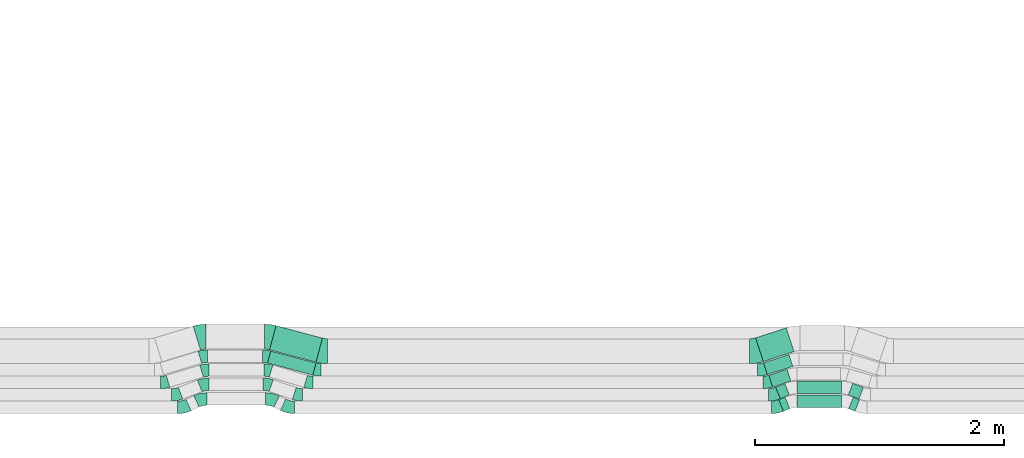
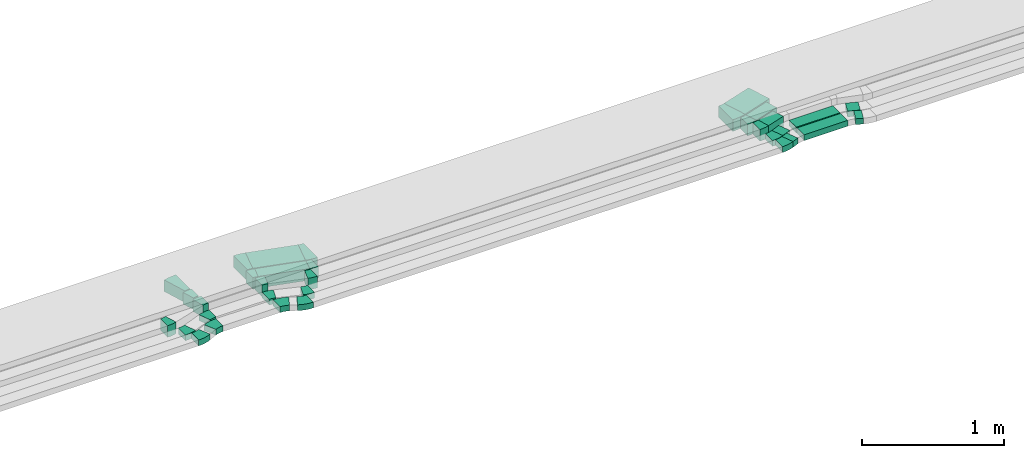
# One storey, part 12 of 28: 23 flow fittings, 11 flow segments.
"""IFC2X3 building model written with IfcOpenShell, lengths in millimetres."""

from ifc_helpers import new_model, entity, si_unit, converted_unit, derived_unit, direction, frame, frame_2d, origin, origin_2d_with_axis, place, context, subcontext, project, spatial, polyline, circle_curve, parameter, trimmed, segment, composite_curve, rectangle, outline, extrude, source, transform, mapped, material, type_object, type_shapes, element, save


model = new_model("IFC2X3")

# Units and contexts
model_context = context("Model", 3, precision=0.01, world=origin(), true_north=direction((6.12303176911189e-17, 1.0)))
body_context = subcontext(model_context, "Body", "Model", "MODEL_VIEW")
ifc_project = project(units=[si_unit("LENGTHUNIT", "METRE", prefix="MILLI"), si_unit("AREAUNIT", "SQUARE_METRE"), si_unit("VOLUMEUNIT", "CUBIC_METRE"), converted_unit("PLANEANGLEUNIT", "DEGREE", entity("IfcRatioMeasure", 0.0174532925199433), si_unit("PLANEANGLEUNIT", "RADIAN"), dimensions=[0, 0, 0, 0, 0, 0, 0]), si_unit("MASSUNIT", "GRAM", prefix="KILO"), derived_unit("MASSDENSITYUNIT", [(si_unit("MASSUNIT", "GRAM", prefix="KILO"), 1), (si_unit("LENGTHUNIT", "METRE"), -3)]), derived_unit("MOMENTOFINERTIAUNIT", [(si_unit("LENGTHUNIT", "METRE"), 4)]), si_unit("TIMEUNIT", "SECOND"), si_unit("FREQUENCYUNIT", "HERTZ"), si_unit("THERMODYNAMICTEMPERATUREUNIT", "DEGREE_CELSIUS"), derived_unit("THERMALTRANSMITTANCEUNIT", [(si_unit("MASSUNIT", "GRAM", prefix="KILO"), 1), (si_unit("THERMODYNAMICTEMPERATUREUNIT", "KELVIN"), -1), (si_unit("TIMEUNIT", "SECOND"), -3)]), derived_unit("VOLUMETRICFLOWRATEUNIT", [(si_unit("LENGTHUNIT", "METRE"), 3), (si_unit("TIMEUNIT", "SECOND"), -1)]), derived_unit("MASSFLOWRATEUNIT", [(si_unit("MASSUNIT", "GRAM", prefix="KILO"), 1), (si_unit("TIMEUNIT", "SECOND"), -1)]), derived_unit("ROTATIONALFREQUENCYUNIT", [(si_unit("TIMEUNIT", "SECOND"), -1)]), si_unit("ELECTRICCURRENTUNIT", "AMPERE"), si_unit("ELECTRICVOLTAGEUNIT", "VOLT"), si_unit("POWERUNIT", "WATT"), si_unit("FORCEUNIT", "NEWTON", prefix="KILO"), si_unit("ILLUMINANCEUNIT", "LUX"), si_unit("LUMINOUSFLUXUNIT", "LUMEN"), si_unit("LUMINOUSINTENSITYUNIT", "CANDELA"), derived_unit("USERDEFINED", [(si_unit("MASSUNIT", "GRAM", prefix="KILO"), -1), (si_unit("LENGTHUNIT", "METRE"), -2), (si_unit("TIMEUNIT", "SECOND"), 3), (si_unit("LUMINOUSFLUXUNIT", "LUMEN"), 1)]), derived_unit("LINEARVELOCITYUNIT", [(si_unit("LENGTHUNIT", "METRE"), 1), (si_unit("TIMEUNIT", "SECOND"), -1)]), si_unit("PRESSUREUNIT", "PASCAL"), derived_unit("USERDEFINED", [(si_unit("LENGTHUNIT", "METRE"), -2), (si_unit("MASSUNIT", "GRAM", prefix="KILO"), 1), (si_unit("TIMEUNIT", "SECOND"), -2)]), derived_unit("LINEARFORCEUNIT", [(si_unit("MASSUNIT", "GRAM", prefix="KILO"), 1), (si_unit("LENGTHUNIT", "METRE"), 1), (si_unit("TIMEUNIT", "SECOND"), -2), (si_unit("LENGTHUNIT", "METRE"), -1)]), derived_unit("PLANARFORCEUNIT", [(si_unit("MASSUNIT", "GRAM", prefix="KILO"), 1), (si_unit("LENGTHUNIT", "METRE"), 1), (si_unit("TIMEUNIT", "SECOND"), -2), (si_unit("LENGTHUNIT", "METRE"), -2)])], contexts=[model_context])

# Site, building, storey
site_placement = place(None, origin())
site = spatial("IfcSite", under=ifc_project, at=site_placement, CompositionType="ELEMENT")
building_placement = place(site_placement, origin())
building = spatial("IfcBuilding", under=site, at=building_placement, CompositionType="ELEMENT")
storey_placement = place(building_placement, frame((0.0, 0.0, 4200.0)))
storey = spatial("IfcBuildingStorey", under=building, at=storey_placement, CompositionType="ELEMENT", Elevation=4200.0)

# Flow segments
cable_carrier_segment_type = type_object("IfcCableCarrierSegmentType", PredefinedType="CABLETRAYSEGMENT")
flow_segment_1_placement = place(storey_placement, frame((26042.3, 555.39, 2836.0)))
element("IfcFlowSegment", 1, at=flow_segment_1_placement, inside=storey, type_object=cable_carrier_segment_type, context=body_context, shape_type="SweptSolid", body=[
    extrude(rectangle(XDim=375.709099375741, YDim=100.000000000002, at=origin_2d_with_axis()), frame((194.39, 96.81, 0.0), z_axis=(0.0, 0.0, 1.0), x_axis=(0.966084121972167, -0.258227553280565, 0.0)), (0.0, 0.0, 1.0), 100.000000000001),
])
flow_segment_2_placement = place(storey_placement, frame((26058.72, 658.79, 2836.0)))
element("IfcFlowSegment", 2, at=flow_segment_2_placement, inside=storey, type_object=cable_carrier_segment_type, context=body_context, shape_type="SweptSolid", body=[
    extrude(rectangle(XDim=385.219495382676, YDim=199.999999999999, at=origin_2d_with_axis()), frame((211.9, 146.35, 0.0), z_axis=(0.0, 0.0, 1.0), x_axis=(0.966084121972157, -0.258227553280602, 0.0)), (0.0, 0.0, 1.0), 100.000000000001),
])
flow_segment_3_placement = place(storey_placement, frame((30142.56, 265.24, 2836.0)))
element("IfcFlowSegment", 3, at=flow_segment_3_placement, inside=storey, type_object=cable_carrier_segment_type, context=body_context, shape_type="SweptSolid", body=[
    extrude(rectangle(XDim=55.2478763448979, YDim=99.9999999999959, at=origin_2d_with_axis()), frame((44.34, 56.71, 0.0), z_axis=(0.0, 0.0, 1.0), x_axis=(0.927183854566641, 0.374606593416275, 0.0)), (0.0, 0.0, 1.0), 49.9999999999994),
])
flow_segment_4_placement = place(storey_placement, frame((30289.37, 297.23, 2836.0)))
element("IfcFlowSegment", 4, at=flow_segment_4_placement, inside=storey, type_object=cable_carrier_segment_type, context=body_context, shape_type="SweptSolid", body=[
    extrude(rectangle(XDim=355.247876344916, YDim=100.0, at=origin_2d_with_axis()), frame((177.62, 50.0, 0.0)), (0.0, 0.0, 1.0), 49.9999999999995),
])
flow_segment_5_placement = place(storey_placement, frame((30702.73, 265.24, 2836.0)))
element("IfcFlowSegment", 5, at=flow_segment_5_placement, inside=storey, type_object=cable_carrier_segment_type, context=body_context, shape_type="SweptSolid", body=[
    extrude(rectangle(XDim=55.2478763449133, YDim=100.0, at=origin_2d_with_axis()), frame((44.34, 56.71, 0.0), z_axis=(0.0, 0.0, 1.0), x_axis=(0.927183854566696, -0.374606593416139, 0.0)), (0.0, 0.0, 1.0), 49.9999999999995),
])
flow_segment_6_placement = place(storey_placement, frame((30117.56, 365.24, 2836.0)))
element("IfcFlowSegment", 6, at=flow_segment_6_placement, inside=storey, type_object=cable_carrier_segment_type, context=body_context, shape_type="SweptSolid", body=[
    extrude(rectangle(XDim=80.2478763448968, YDim=100.000000000003, at=origin_2d_with_axis()), frame((55.93, 61.39, 0.0), z_axis=(0.0, 0.0, 1.0), x_axis=(0.92718385456639, 0.374606593416895, 0.0)), (0.0, 0.0, 1.0), 49.9999999999994),
])
flow_segment_7_placement = place(storey_placement, frame((30287.55, 406.59, 2836.0)))
element("IfcFlowSegment", 7, at=flow_segment_7_placement, inside=storey, type_object=cable_carrier_segment_type, context=body_context, shape_type="SweptSolid", body=[
    extrude(rectangle(XDim=357.168656212116, YDim=100.0, at=origin_2d_with_axis()), frame((178.58, 50.0, 0.0)), (0.0, 0.0, 1.0), 49.9999999999995),
])
flow_segment_8_placement = place(storey_placement, frame((30700.25, 363.52, 2836.0)))
element("IfcFlowSegment", 8, at=flow_segment_8_placement, inside=storey, type_object=cable_carrier_segment_type, context=body_context, shape_type="SweptSolid", body=[
    extrude(rectangle(XDim=91.8149731757522, YDim=99.9999999999983, at=origin_2d_with_axis()), frame((60.74, 63.1, 0.0), z_axis=(0.0, 0.0, 1.0), x_axis=(-0.933969781710923, 0.357351992929731, 0.0)), (0.0, 0.0, 1.0), 49.9999999999995),
])
flow_segment_9_placement = place(storey_placement, frame((30062.67, 459.2, 2836.0)))
element("IfcFlowSegment", 9, at=flow_segment_9_placement, inside=storey, type_object=cable_carrier_segment_type, context=body_context, shape_type="SweptSolid", body=[
    extrude(rectangle(XDim=154.646223870172, YDim=100.000000000002, at=origin_2d_with_axis()), frame((88.99, 71.45, 0.0), z_axis=(0.0, 0.0, 1.0), x_axis=(0.951056516295111, 0.309016994375079, 0.0)), (0.0, 0.0, 1.0), 99.9999999999989),
])
flow_segment_10_placement = place(storey_placement, frame((30020.15, 559.2, 2836.0)))
element("IfcFlowSegment", 10, at=flow_segment_10_placement, inside=storey, type_object=cable_carrier_segment_type, context=body_context, shape_type="SweptSolid", body=[
    extrude(rectangle(XDim=214.646223870171, YDim=99.9999999999981, at=origin_2d_with_axis()), frame((117.52, 80.72, 0.0), z_axis=(0.0, 0.0, 1.0), x_axis=(0.951056516295066, 0.309016994375216, 0.0)), (0.0, 0.0, 1.0), 99.9999999999989),
])
flow_segment_11_placement = place(storey_placement, frame((29957.09, 664.1, 2836.0)))
element("IfcFlowSegment", 11, at=flow_segment_11_placement, inside=storey, type_object=cable_carrier_segment_type, context=body_context, shape_type="SweptSolid", body=[
    extrude(rectangle(XDim=258.80777983768, YDim=199.999999999997, at=origin_2d_with_axis()), frame((153.97, 135.09, 0.0), z_axis=(0.0, 0.0, 1.0), x_axis=(0.951056516295083, 0.309016994375165, 0.0)), (0.0, 0.0, 1.0), 99.9999999999989),
])

# Flow fittings
ifc_material = material()
cable_carrier_fitting_type_1 = type_object("IfcCableCarrierFittingType", Name="470_DKC_S5_Variable Angle Elbow 0-45:-", PredefinedType="NOTDEFINED", material=ifc_material)
shared_shape_1 = source(origin(), body_context, "Body", "SweptSolid", [
    extrude(outline(composite_curve([segment(polyline([(-38.44, -57.38), (-37.44, -57.38)]), True, "CONTINUOUS"), segment(trimmed(circle_curve(frame_2d((-37.44, 192.62), x_axis=(0.0, -1.0)), 250.0), [parameter(0.0)], [parameter(22.0)], True, "PARAMETER"), True, "CONTINUOUS"), segment(polyline([(56.21, -39.17), (57.14, -38.8)]), True, "CONTINUOUS"), segment(polyline([(57.14, -38.8), (19.68, 53.92)]), True, "CONTINUOUS"), segment(polyline([(19.68, 53.92), (18.75, 53.55)]), True, "CONTINUOUS"), segment(trimmed(circle_curve(frame_2d((-37.44, 192.62), x_axis=(0.0, -1.0)), 150.0), [parameter(0.0)], [parameter(22.0)], True, "PARAMETER"), False, "CONTINUOUS"), segment(polyline([(-37.44, 42.62), (-38.44, 42.62)]), True, "CONTINUOUS"), segment(polyline([(-38.44, 42.62), (-38.44, -57.38)]), True, "CONTINUOUS")], self_intersect=False)), frame((-1.43, 7.38, -25.0)), (0.0, 0.0, 1.0), 50.0000000000001),
])
type_shapes(cable_carrier_fitting_type_1, [shared_shape_1])
for number, where, name in (
    (12, (30124.32, 296.66, 2861.0), "470_DKC_S5_Variable Angle Elbow 0-45:-"),
    (13, (30099.32, 396.66, 2861.0), "470_DKC_S5_Variable Angle Elbow 0-45:-"),
):
    element("IfcFlowFitting", number, at=place(storey_placement, frame(where)), inside=storey, type_object=cable_carrier_fitting_type_1, material=ifc_material, Name=name, ObjectType="470_DKC_S5_Variable Angle Elbow 0-45:-", context=body_context, shape_type="MappedRepresentation", body=[
        mapped(shared_shape_1, transform((0.0, 0.0, 0.0), scale=1.0)),
    ])
cable_carrier_fitting_type_2 = type_object("IfcCableCarrierFittingType", Name="470_DKC_S5_Variable Angle Elbow 0-45:-", PredefinedType="NOTDEFINED", material=ifc_material)
shared_shape_2 = source(origin(), body_context, "Body", "SweptSolid", [
    extrude(outline(composite_curve([segment(polyline([(-43.24, -59.47), (-42.24, -59.47)]), True, "CONTINUOUS"), segment(trimmed(circle_curve(frame_2d((-42.24, 190.53), x_axis=(0.0, -1.0)), 250.0), [parameter(0.0)], [parameter(24.9999999999996)], True, "PARAMETER"), True, "CONTINUOUS"), segment(polyline([(63.42, -36.05), (64.32, -35.63)]), True, "CONTINUOUS"), segment(polyline([(64.32, -35.63), (22.06, 55.0)]), True, "CONTINUOUS"), segment(polyline([(22.06, 55.0), (21.15, 54.58)]), True, "CONTINUOUS"), segment(trimmed(circle_curve(frame_2d((-42.24, 190.53), x_axis=(0.0, -1.0)), 150.0), [parameter(0.0)], [parameter(24.9999999999996)], True, "PARAMETER"), False, "CONTINUOUS"), segment(polyline([(-42.24, 40.53), (-43.24, 40.53)]), True, "CONTINUOUS"), segment(polyline([(-43.24, 40.53), (-43.24, -59.47)]), True, "CONTINUOUS")], self_intersect=False)), frame((-2.1, 9.47, -25.0)), (0.0, 0.0, 1.0), 50.0),
])
type_shapes(cable_carrier_fitting_type_2, [shared_shape_2])
flow_fitting_1_placement = place(storey_placement, frame((25367.56, 296.66, 2861.0)))
element("IfcFlowFitting", 14, at=flow_fitting_1_placement, inside=storey, type_object=cable_carrier_fitting_type_2, material=ifc_material, Name="470_DKC_S5_Variable Angle Elbow 0-45:-", ObjectType="470_DKC_S5_Variable Angle Elbow 0-45:-", context=body_context, shape_type="MappedRepresentation", body=[
    mapped(shared_shape_2, transform((0.0, 0.0, 0.0), scale=1.0)),
])
flow_fitting_2_placement = place(storey_placement, frame((25512.57, 364.28, 2861.0), z_axis=(0.0, 0.0, 1.0), x_axis=(-1.0, 0.0, 0.0)))
element("IfcFlowFitting", 15, at=flow_fitting_2_placement, inside=storey, type_object=cable_carrier_fitting_type_2, material=ifc_material, Name="470_DKC_S5_Variable Angle Elbow 0-45:-", ObjectType="470_DKC_S5_Variable Angle Elbow 0-45:-", context=body_context, shape_type="MappedRepresentation", body=[
    mapped(shared_shape_2, transform((0.0, 0.0, 0.0), scale=1.0)),
])
cable_carrier_fitting_type_3 = type_object("IfcCableCarrierFittingType", Name="470_DKC_S5_Variable Angle Elbow 0-45:-", PredefinedType="NOTDEFINED", material=ifc_material)
shared_shape_3 = source(origin(), body_context, "Body", "SweptSolid", [
    extrude(outline(composite_curve([segment(polyline([(-45.3, -60.47), (-44.3, -60.47)]), True, "CONTINUOUS"), segment(trimmed(circle_curve(frame_2d((-44.3, 189.53), x_axis=(0.0, -1.0)), 250.0), [parameter(0.0)], [parameter(26.311268547247)], True, "PARAMETER"), True, "CONTINUOUS"), segment(polyline([(66.51, -34.57), (67.41, -34.13)]), True, "CONTINUOUS"), segment(polyline([(67.41, -34.13), (23.08, 55.51)]), True, "CONTINUOUS"), segment(polyline([(23.08, 55.51), (22.19, 55.07)]), True, "CONTINUOUS"), segment(trimmed(circle_curve(frame_2d((-44.3, 189.53), x_axis=(0.0, -1.0)), 150.0), [parameter(0.0)], [parameter(26.311268547247)], True, "PARAMETER"), False, "CONTINUOUS"), segment(polyline([(-44.3, 39.53), (-45.3, 39.53)]), True, "CONTINUOUS"), segment(polyline([(-45.3, 39.53), (-45.3, -60.47)]), True, "CONTINUOUS")], self_intersect=False)), frame((-2.45, 10.47, -25.0)), (0.0, 0.0, 1.0), 50.0),
])
type_shapes(cable_carrier_fitting_type_3, [shared_shape_3])
for number, where, z_axis, x_axis, name in (
    (16, (26209.32, 296.66, 2861.0), (0.0, 0.0, 1.0), (0.896399272794063, -0.443247497155118, 0.0), "470_DKC_S5_Variable Angle Elbow 0-45:-"),
    (17, (26072.57, 364.28, 2861.0), (0.0, 0.0, 1.0), (-0.896399272793994, 0.443247497155257, 0.0), "470_DKC_S5_Variable Angle Elbow 0-45:-"),
):
    element("IfcFlowFitting", number, at=place(storey_placement, frame(where, z_axis=z_axis, x_axis=x_axis)), inside=storey, type_object=cable_carrier_fitting_type_3, material=ifc_material, Name=name, ObjectType="470_DKC_S5_Variable Angle Elbow 0-45:-", context=body_context, shape_type="MappedRepresentation", body=[
        mapped(shared_shape_3, transform((0.0, 0.0, 0.0), scale=1.0)),
    ])
cable_carrier_fitting_type_4 = type_object("IfcCableCarrierFittingType", Name="470_DKC_S5_Variable Angle Elbow 0-45:-", PredefinedType="NOTDEFINED", material=ifc_material)
shared_shape_4 = source(origin(), body_context, "Body", "SweptSolid", [
    extrude(outline(composite_curve([segment(polyline([(-36.82, -56.73), (-35.82, -56.73)]), True, "CONTINUOUS"), segment(trimmed(circle_curve(frame_2d((-35.82, 193.27), x_axis=(0.0, -1.0)), 250.0), [parameter(0.0)], [parameter(21.0)], True, "PARAMETER"), True, "CONTINUOUS"), segment(polyline([(53.77, -40.13), (54.71, -39.77)]), True, "CONTINUOUS"), segment(polyline([(54.71, -39.77), (18.87, 53.59)]), True, "CONTINUOUS"), segment(polyline([(18.87, 53.59), (17.94, 53.23)]), True, "CONTINUOUS"), segment(trimmed(circle_curve(frame_2d((-35.82, 193.27), x_axis=(0.0, -1.0)), 150.0), [parameter(0.0)], [parameter(21.0)], True, "PARAMETER"), False, "CONTINUOUS"), segment(polyline([(-35.82, 43.27), (-36.82, 43.27)]), True, "CONTINUOUS"), segment(polyline([(-36.82, 43.27), (-36.82, -56.73)]), True, "CONTINUOUS")], self_intersect=False)), frame((-1.25, 6.73, -25.0)), (0.0, 0.0, 1.0), 50.0000000000001),
])
type_shapes(cable_carrier_fitting_type_4, [shared_shape_4])
flow_fitting_3_placement = place(storey_placement, frame((25309.76, 396.66, 2861.0)))
element("IfcFlowFitting", 18, at=flow_fitting_3_placement, inside=storey, type_object=cable_carrier_fitting_type_4, material=ifc_material, Name="470_DKC_S5_Variable Angle Elbow 0-45:-", ObjectType="470_DKC_S5_Variable Angle Elbow 0-45:-", context=body_context, shape_type="MappedRepresentation", body=[
    mapped(shared_shape_4, transform((0.0, 0.0, 0.0), scale=1.0)),
])
flow_fitting_4_placement = place(storey_placement, frame((25533.82, 482.67, 2861.0), z_axis=(0.0, 0.0, 1.0), x_axis=(-1.0, 0.0, 0.0)))
element("IfcFlowFitting", 19, at=flow_fitting_4_placement, inside=storey, type_object=cable_carrier_fitting_type_4, material=ifc_material, Name="470_DKC_S5_Variable Angle Elbow 0-45:-", ObjectType="470_DKC_S5_Variable Angle Elbow 0-45:-", context=body_context, shape_type="MappedRepresentation", body=[
    mapped(shared_shape_4, transform((0.0, 0.0, 0.0), scale=1.0)),
])
cable_carrier_fitting_type_5 = type_object("IfcCableCarrierFittingType", Name="470_DKC_S5_Variable Angle Elbow 0-45:-", PredefinedType="NOTDEFINED", material=ifc_material)
shared_shape_5 = source(origin(), body_context, "Body", "SweptSolid", [
    extrude(outline(composite_curve([segment(polyline([(-33.48, -55.51), (-32.48, -55.51)]), True, "CONTINUOUS"), segment(trimmed(circle_curve(frame_2d((-32.48, 194.49), x_axis=(0.0, -1.0)), 250.0), [parameter(0.0)], [parameter(18.9587695616004)], True, "PARAMETER"), True, "CONTINUOUS"), segment(polyline([(48.75, -41.94), (49.69, -41.62)]), True, "CONTINUOUS"), segment(polyline([(49.69, -41.62), (17.2, 52.96)]), True, "CONTINUOUS"), segment(polyline([(17.2, 52.96), (16.26, 52.63)]), True, "CONTINUOUS"), segment(trimmed(circle_curve(frame_2d((-32.48, 194.49), x_axis=(0.0, -1.0)), 150.0), [parameter(0.0)], [parameter(18.9587695616004)], True, "PARAMETER"), False, "CONTINUOUS"), segment(polyline([(-32.48, 44.49), (-33.48, 44.49)]), True, "CONTINUOUS"), segment(polyline([(-33.48, 44.49), (-33.48, -55.51)]), True, "CONTINUOUS")], self_intersect=False)), frame((-0.92, 5.51, -25.0)), (0.0, 0.0, 1.0), 50.0000000000001),
])
type_shapes(cable_carrier_fitting_type_5, [shared_shape_5])
for number, where, z_axis, x_axis, name in (
    (20, (26289.32, 396.66, 2861.0), (0.0, 0.0, 1.0), (0.945752611859286, -0.324887668527659, 0.0), "470_DKC_S5_Variable Angle Elbow 0-45:-"),
    (21, (26038.95, 482.67, 2861.0), (0.0, 0.0, 1.0), (-0.945752611859261, 0.324887668527733, 0.0), "470_DKC_S5_Variable Angle Elbow 0-45:-"),
):
    element("IfcFlowFitting", number, at=place(storey_placement, frame(where, z_axis=z_axis, x_axis=x_axis)), inside=storey, type_object=cable_carrier_fitting_type_5, material=ifc_material, Name=name, ObjectType="470_DKC_S5_Variable Angle Elbow 0-45:-", context=body_context, shape_type="MappedRepresentation", body=[
        mapped(shared_shape_5, transform((0.0, 0.0, 0.0), scale=1.0)),
    ])
cable_carrier_fitting_type_6 = type_object("IfcCableCarrierFittingType", Name="470_DKC_S5_Variable Angle Elbow 0-45:-", PredefinedType="NOTDEFINED", material=ifc_material)
shared_shape_6 = source(origin(), body_context, "Body", "SweptSolid", [
    extrude(outline(composite_curve([segment(polyline([(-30.23, -54.44), (-29.23, -54.44)]), True, "CONTINUOUS"), segment(trimmed(circle_curve(frame_2d((-29.23, 195.56), x_axis=(0.0, -1.0)), 250.0), [parameter(0.0)], [parameter(17.0)], True, "PARAMETER"), True, "CONTINUOUS"), segment(polyline([(43.87, -43.52), (44.82, -43.23)]), True, "CONTINUOUS"), segment(polyline([(44.82, -43.23), (15.59, 52.4)]), True, "CONTINUOUS"), segment(polyline([(15.59, 52.4), (14.63, 52.11)]), True, "CONTINUOUS"), segment(trimmed(circle_curve(frame_2d((-29.23, 195.56), x_axis=(0.0, -1.0)), 150.0), [parameter(0.0)], [parameter(17.0)], True, "PARAMETER"), False, "CONTINUOUS"), segment(polyline([(-29.23, 45.56), (-30.23, 45.56)]), True, "CONTINUOUS"), segment(polyline([(-30.23, 45.56), (-30.23, -54.44)]), True, "CONTINUOUS")], self_intersect=False)), frame((-0.66, 4.44, -50.0)), (0.0, 0.0, 1.0), 100.0),
])
type_shapes(cable_carrier_fitting_type_6, [shared_shape_6])
flow_fitting_5_placement = place(storey_placement, frame((25215.36, 496.66, 2886.0)))
element("IfcFlowFitting", 22, at=flow_fitting_5_placement, inside=storey, type_object=cable_carrier_fitting_type_6, material=ifc_material, Name="470_DKC_S5_Variable Angle Elbow 0-45:-", ObjectType="470_DKC_S5_Variable Angle Elbow 0-45:-", context=body_context, shape_type="MappedRepresentation", body=[
    mapped(shared_shape_6, transform((0.0, 0.0, 0.0), scale=1.0)),
])
for number, where, z_axis, x_axis, name in (
    (23, (25542.44, 596.66, 2886.0), (0.0, 0.0, 1.0), (-1.0, 0.0, 0.0), "470_DKC_S5_Variable Angle Elbow 0-45:-"),
    (24, (25528.87, 707.76, 2886.0), (0.0, 0.0, 1.0), (-1.0, 0.0, 0.0), "470_DKC_S5_Variable Angle Elbow 0-45:-"),
):
    element("IfcFlowFitting", number, at=place(storey_placement, frame(where, z_axis=z_axis, x_axis=x_axis)), inside=storey, type_object=cable_carrier_fitting_type_6, material=ifc_material, Name=name, ObjectType="470_DKC_S5_Variable Angle Elbow 0-45:-", context=body_context, shape_type="MappedRepresentation", body=[
        mapped(shared_shape_6, transform((0.0, 0.0, 0.0), scale=1.0)),
    ])
cable_carrier_fitting_type_7 = type_object("IfcCableCarrierFittingType", Name="470_DKC_S5_Variable Angle Elbow 0-45:-", PredefinedType="NOTDEFINED", material=ifc_material)
shared_shape_7 = source(origin(), body_context, "Body", "SweptSolid", [
    extrude(outline(composite_curve([segment(polyline([(-29.62, -54.26), (-28.62, -54.26)]), True, "CONTINUOUS"), segment(trimmed(circle_curve(frame_2d((-28.62, 195.74), x_axis=(0.0, -1.0)), 250.0), [parameter(0.0)], [parameter(16.6397728105934)], True, "PARAMETER"), True, "CONTINUOUS"), segment(polyline([(42.96, -43.79), (43.92, -43.5)]), True, "CONTINUOUS"), segment(polyline([(43.92, -43.5), (15.29, 52.31)]), True, "CONTINUOUS"), segment(polyline([(15.29, 52.31), (14.33, 52.02)]), True, "CONTINUOUS"), segment(trimmed(circle_curve(frame_2d((-28.62, 195.74), x_axis=(0.0, -1.0)), 150.0), [parameter(0.0)], [parameter(16.6397728105934)], True, "PARAMETER"), False, "CONTINUOUS"), segment(polyline([(-28.62, 45.74), (-29.62, 45.74)]), True, "CONTINUOUS"), segment(polyline([(-29.62, 45.74), (-29.62, -54.26)]), True, "CONTINUOUS")], self_intersect=False)), frame((-0.62, 4.26, -50.0)), (0.0, 0.0, 1.0), 100.0),
])
type_shapes(cable_carrier_fitting_type_7, [shared_shape_7])
for number, where, z_axis, x_axis, name in (
    (25, (26377.04, 496.66, 2886.0), (0.0, 0.0, 1.0), (0.958124028295574, -0.286353533944775, 0.0), "470_DKC_S5_Variable Angle Elbow 0-45:-"),
    (26, (26042.44, 596.66, 2886.0), (0.0, 0.0, 1.0), (-0.958124028295565, 0.286353533944807, 0.0), "470_DKC_S5_Variable Angle Elbow 0-45:-"),
):
    element("IfcFlowFitting", number, at=place(storey_placement, frame(where, z_axis=z_axis, x_axis=x_axis)), inside=storey, type_object=cable_carrier_fitting_type_7, material=ifc_material, Name=name, ObjectType="470_DKC_S5_Variable Angle Elbow 0-45:-", context=body_context, shape_type="MappedRepresentation", body=[
        mapped(shared_shape_7, transform((0.0, 0.0, 0.0), scale=1.0)),
    ])
cable_carrier_fitting_type_8 = type_object("IfcCableCarrierFittingType", Name="470_DKC_S5_Variable Angle Elbow 0-45:-", PredefinedType="NOTDEFINED", material=ifc_material)
shared_shape_8 = source(origin(), body_context, "Body", "SweptSolid", [
    extrude(outline(composite_curve([segment(polyline([(-26.81, -53.46), (-25.81, -53.46)]), True, "CONTINUOUS"), segment(trimmed(circle_curve(frame_2d((-25.81, 196.54), x_axis=(0.0, -1.0)), 250.0), [parameter(0.0)], [parameter(14.9649173815194)], True, "PARAMETER"), True, "CONTINUOUS"), segment(polyline([(38.74, -44.98), (39.71, -44.72)]), True, "CONTINUOUS"), segment(polyline([(39.71, -44.72), (13.89, 51.89)]), True, "CONTINUOUS"), segment(polyline([(13.89, 51.89), (12.92, 51.63)]), True, "CONTINUOUS"), segment(trimmed(circle_curve(frame_2d((-25.81, 196.54), x_axis=(0.0, -1.0)), 150.0), [parameter(0.0)], [parameter(14.9649173815194)], True, "PARAMETER"), False, "CONTINUOUS"), segment(polyline([(-25.81, 46.54), (-26.81, 46.54)]), True, "CONTINUOUS"), segment(polyline([(-26.81, 46.54), (-26.81, -53.46)]), True, "CONTINUOUS")], self_intersect=False)), frame((-0.45, 3.46, -50.0)), (0.0, 0.0, 1.0), 100.0),
])
type_shapes(cable_carrier_fitting_type_8, [shared_shape_8])
for number, where, z_axis, x_axis, name in (
    (27, (26028.87, 707.76, 2886.0), (0.0, 0.0, 1.0), (-0.966084121972172, 0.258227553280546, 0.0), "470_DKC_S5_Variable Angle Elbow 0-45:-"),
    (28, (26444.52, 596.66, 2886.0), (0.0, 0.0, 1.0), (0.966084121972167, -0.258227553280564, 0.0), "470_DKC_S5_Variable Angle Elbow 0-45:-"),
):
    element("IfcFlowFitting", number, at=place(storey_placement, frame(where, z_axis=z_axis, x_axis=x_axis)), inside=storey, type_object=cable_carrier_fitting_type_8, material=ifc_material, Name=name, ObjectType="470_DKC_S5_Variable Angle Elbow 0-45:-", context=body_context, shape_type="MappedRepresentation", body=[
        mapped(shared_shape_8, transform((0.0, 0.0, 0.0), scale=1.0)),
    ])
cable_carrier_fitting_type_9 = type_object("IfcCableCarrierFittingType", Name="470_DKC_S5_Variable Angle Elbow 0-45:-", PredefinedType="NOTDEFINED", material=ifc_material)
shared_shape_9 = source(origin(), body_context, "Body", "SweptSolid", [
    extrude(outline(composite_curve([segment(polyline([(-37.54, -105.53), (-36.54, -105.53)]), True, "CONTINUOUS"), segment(trimmed(circle_curve(frame_2d((-36.54, 244.47), x_axis=(0.0, -1.0)), 350.0), [parameter(0.0)], [parameter(17.0000000000041)], True, "PARAMETER"), True, "CONTINUOUS"), segment(polyline([(65.79, -90.24), (66.75, -89.95)]), True, "CONTINUOUS"), segment(polyline([(66.75, -89.95), (8.28, 101.31)]), True, "CONTINUOUS"), segment(polyline([(8.28, 101.31), (7.32, 101.02)]), True, "CONTINUOUS"), segment(trimmed(circle_curve(frame_2d((-36.54, 244.47), x_axis=(0.0, -1.0)), 150.0), [parameter(0.0)], [parameter(17.0000000000041)], True, "PARAMETER"), False, "CONTINUOUS"), segment(polyline([(-36.54, 94.47), (-37.54, 94.47)]), True, "CONTINUOUS"), segment(polyline([(-37.54, 94.47), (-37.54, -105.53)]), True, "CONTINUOUS")], self_intersect=False)), frame((-0.83, 5.53, -50.0)), (0.0, 0.0, 1.0), 100.0),
])
type_shapes(cable_carrier_fitting_type_9, [shared_shape_9])
flow_fitting_6_placement = place(storey_placement, frame((25511.86, 863.61, 2886.0), z_axis=(0.0, 0.0, 1.0), x_axis=(-1.0, 0.0, 0.0)))
element("IfcFlowFitting", 29, at=flow_fitting_6_placement, inside=storey, type_object=cable_carrier_fitting_type_9, material=ifc_material, Name="470_DKC_S5_Variable Angle Elbow 0-45:-", ObjectType="470_DKC_S5_Variable Angle Elbow 0-45:-", context=body_context, shape_type="MappedRepresentation", body=[
    mapped(shared_shape_9, transform((0.0, 0.0, 0.0), scale=1.0)),
])
cable_carrier_fitting_type_10 = type_object("IfcCableCarrierFittingType", Name="470_DKC_S5_Variable Angle Elbow 0-45:-", PredefinedType="NOTDEFINED", material=ifc_material)
shared_shape_10 = source(origin(), body_context, "Body", "SweptSolid", [
    extrude(outline(composite_curve([segment(polyline([(-33.27, -104.3), (-32.27, -104.3)]), True, "CONTINUOUS"), segment(trimmed(circle_curve(frame_2d((-32.27, 245.7), x_axis=(0.0, -1.0)), 350.0), [parameter(0.0)], [parameter(14.9649173815217)], True, "PARAMETER"), True, "CONTINUOUS"), segment(polyline([(58.11, -92.43), (59.08, -92.18)]), True, "CONTINUOUS"), segment(polyline([(59.08, -92.18), (7.43, 101.04)]), True, "CONTINUOUS"), segment(polyline([(7.43, 101.04), (6.46, 100.78)]), True, "CONTINUOUS"), segment(trimmed(circle_curve(frame_2d((-32.27, 245.7), x_axis=(0.0, -1.0)), 150.0), [parameter(0.0)], [parameter(14.9649173815217)], True, "PARAMETER"), False, "CONTINUOUS"), segment(polyline([(-32.27, 95.7), (-33.27, 95.7)]), True, "CONTINUOUS"), segment(polyline([(-33.27, 95.7), (-33.27, -104.3)]), True, "CONTINUOUS")], self_intersect=False)), frame((-0.57, 4.3, -50.0)), (0.0, 0.0, 1.0), 100.0),
])
type_shapes(cable_carrier_fitting_type_10, [shared_shape_10])
for number, where, z_axis, x_axis, name in (
    (30, (26051.86, 863.61, 2886.0), (0.0, 0.0, 1.0), (-0.966084121972167, 0.258227553280567, 0.0), "470_DKC_S5_Variable Angle Elbow 0-45:-"),
    (31, (26489.39, 746.66, 2886.0), (0.0, 0.0, 1.0), (0.966084121972157, -0.258227553280602, 0.0), "470_DKC_S5_Variable Angle Elbow 0-45:-"),
):
    element("IfcFlowFitting", number, at=place(storey_placement, frame(where, z_axis=z_axis, x_axis=x_axis)), inside=storey, type_object=cable_carrier_fitting_type_10, material=ifc_material, Name=name, ObjectType="470_DKC_S5_Variable Angle Elbow 0-45:-", context=body_context, shape_type="MappedRepresentation", body=[
        mapped(shared_shape_10, transform((0.0, 0.0, 0.0), scale=1.0)),
    ])
cable_carrier_fitting_type_11 = type_object("IfcCableCarrierFittingType", Name="470_DKC_S5_Variable Angle Elbow 0-45:-", PredefinedType="NOTDEFINED", material=ifc_material)
shared_shape_11 = source(origin(), body_context, "Body", "SweptSolid", [
    extrude(outline(composite_curve([segment(polyline([(-31.89, -54.97), (-30.89, -54.97)]), True, "CONTINUOUS"), segment(trimmed(circle_curve(frame_2d((-30.89, 195.03), x_axis=(0.0, -1.0)), 250.0), [parameter(0.0)], [parameter(18.0)], True, "PARAMETER"), True, "CONTINUOUS"), segment(polyline([(46.36, -42.74), (47.32, -42.43)]), True, "CONTINUOUS"), segment(polyline([(47.32, -42.43), (16.41, 52.68)]), True, "CONTINUOUS"), segment(polyline([(16.41, 52.68), (15.46, 52.37)]), True, "CONTINUOUS"), segment(trimmed(circle_curve(frame_2d((-30.89, 195.03), x_axis=(0.0, -1.0)), 150.0), [parameter(0.0)], [parameter(18.0)], True, "PARAMETER"), False, "CONTINUOUS"), segment(polyline([(-30.89, 45.03), (-31.89, 45.03)]), True, "CONTINUOUS"), segment(polyline([(-31.89, 45.03), (-31.89, -54.97)]), True, "CONTINUOUS")], self_intersect=False)), frame((-0.79, 4.97, -50.0)), (0.0, 0.0, 1.0), 100.0),
])
type_shapes(cable_carrier_fitting_type_11, [shared_shape_11])
for number, where, name in (
    (32, (30047.04, 496.66, 2886.0), "470_DKC_S5_Variable Angle Elbow 0-45:-"),
    (33, (30004.52, 596.66, 2886.0), "470_DKC_S5_Variable Angle Elbow 0-45:-"),
):
    element("IfcFlowFitting", number, at=place(storey_placement, frame(where)), inside=storey, type_object=cable_carrier_fitting_type_11, material=ifc_material, Name=name, ObjectType="470_DKC_S5_Variable Angle Elbow 0-45:-", context=body_context, shape_type="MappedRepresentation", body=[
        mapped(shared_shape_11, transform((0.0, 0.0, 0.0), scale=1.0)),
    ])
cable_carrier_fitting_type_12 = type_object("IfcCableCarrierFittingType", Name="470_DKC_S5_Variable Angle Elbow 0-45:-", PredefinedType="NOTDEFINED", material=ifc_material)
shared_shape_12 = source(origin(), body_context, "Body", "SweptSolid", [
    extrude(outline(composite_curve([segment(polyline([(-39.61, -106.2), (-38.61, -106.2)]), True, "CONTINUOUS"), segment(trimmed(circle_curve(frame_2d((-38.61, 243.8), x_axis=(0.0, -1.0)), 350.0), [parameter(0.0)], [parameter(18.0000000000079)], True, "PARAMETER"), True, "CONTINUOUS"), segment(polyline([(69.54, -89.06), (70.49, -88.76)]), True, "CONTINUOUS"), segment(polyline([(70.49, -88.76), (8.69, 101.46)]), True, "CONTINUOUS"), segment(polyline([(8.69, 101.46), (7.74, 101.15)]), True, "CONTINUOUS"), segment(trimmed(circle_curve(frame_2d((-38.61, 243.8), x_axis=(0.0, -1.0)), 150.0), [parameter(0.0)], [parameter(18.0000000000079)], True, "PARAMETER"), False, "CONTINUOUS"), segment(polyline([(-38.61, 93.8), (-39.61, 93.8)]), True, "CONTINUOUS"), segment(polyline([(-39.61, 93.8), (-39.61, -106.2)]), True, "CONTINUOUS")], self_intersect=False)), frame((-0.98, 6.2, -50.0)), (0.0, 0.0, 1.0), 100.0),
])
type_shapes(cable_carrier_fitting_type_12, [shared_shape_12])
flow_fitting_7_placement = place(storey_placement, frame((29949.39, 746.66, 2886.0)))
element("IfcFlowFitting", 34, at=flow_fitting_7_placement, inside=storey, type_object=cable_carrier_fitting_type_12, material=ifc_material, Name="470_DKC_S5_Variable Angle Elbow 0-45:-", ObjectType="470_DKC_S5_Variable Angle Elbow 0-45:-", context=body_context, shape_type="MappedRepresentation", body=[
    mapped(shared_shape_12, transform((0.0, 0.0, 0.0), scale=1.0)),
])

save(model, "model.ifc")
